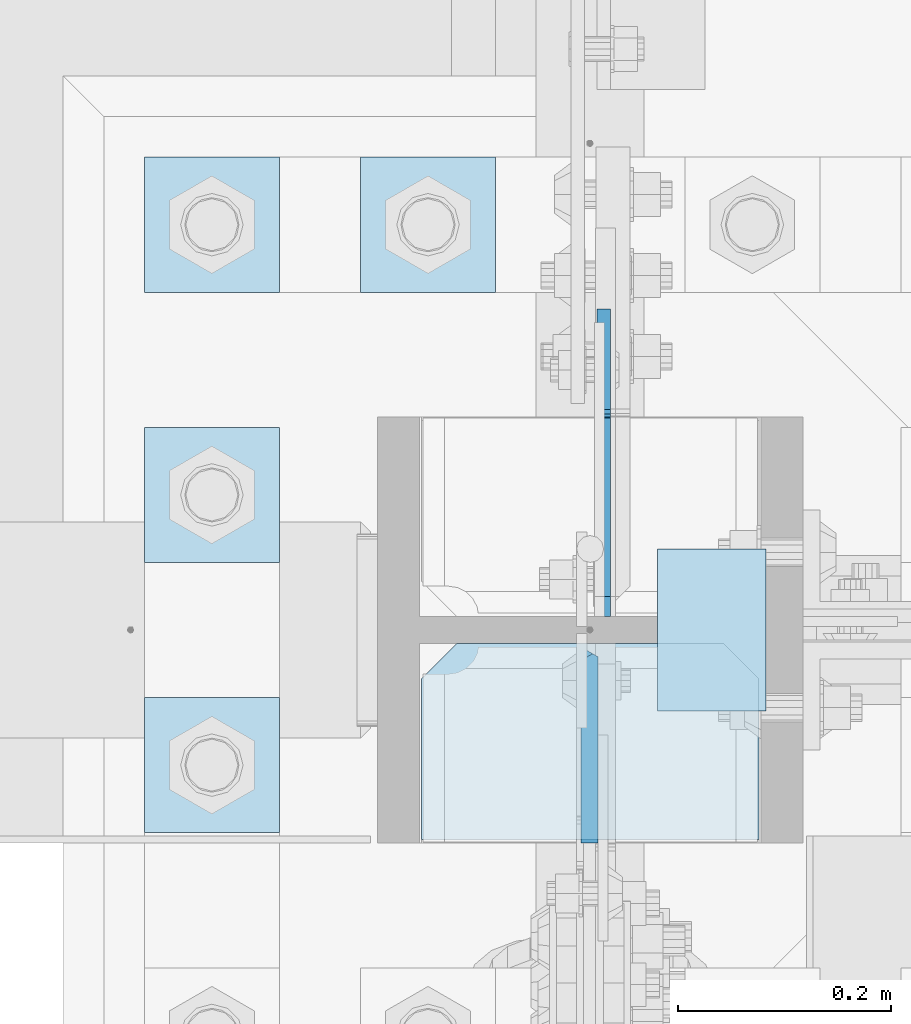
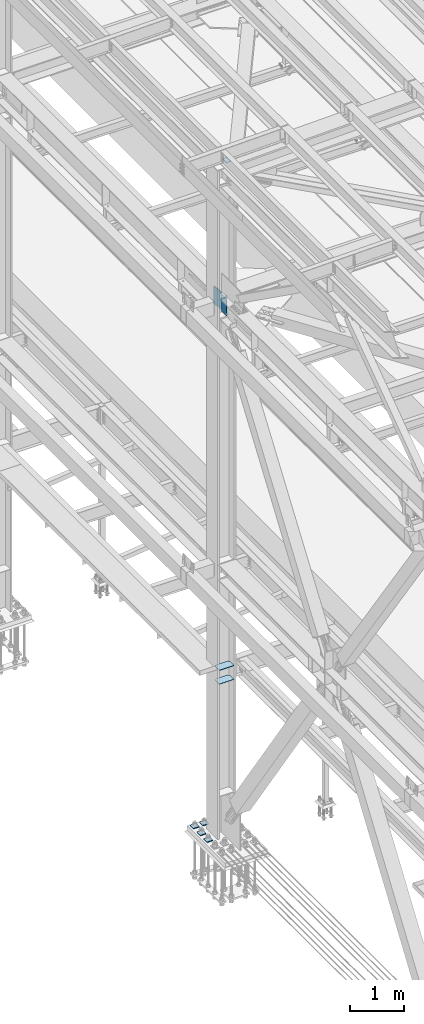
# One storey, part 3272 of 3843: 9 plates, 2 elements without a shape of their own.
"""IFC2X3 building model written with IfcOpenShell, lengths in millimetres."""

from ifc_helpers import new_model, si_unit, frame, origin_with_axes, place, context, subcontext, project, spatial, faceted_brep, material, type_object, element, aggregate, save


model = new_model("IFC2X3")

# Units and contexts
model_context = context("Model", 3, precision=1e-05, world=origin_with_axes())
body_context = subcontext(model_context, "Body", "Model", "MODEL_VIEW")
ifc_project = project(units=[si_unit("LENGTHUNIT", "METRE", prefix="MILLI"), si_unit("AREAUNIT", "SQUARE_METRE"), si_unit("VOLUMEUNIT", "CUBIC_METRE"), si_unit("MASSUNIT", "GRAM", prefix="KILO"), si_unit("TIMEUNIT", "SECOND"), si_unit("PLANEANGLEUNIT", "RADIAN"), si_unit("SOLIDANGLEUNIT", "STERADIAN"), si_unit("THERMODYNAMICTEMPERATUREUNIT", "DEGREE_CELSIUS"), si_unit("LUMINOUSINTENSITYUNIT", "LUMEN")], contexts=[model_context])

# Site, building, storey
site_placement = place(None, origin_with_axes())
site = spatial("IfcSite", under=ifc_project, at=site_placement, CompositionType="ELEMENT")
building_placement = place(site_placement, origin_with_axes())
building = spatial("IfcBuilding", under=site, at=building_placement, Name="Undefined", CompositionType="ELEMENT")
storey_placement = place(building_placement, origin_with_axes())
storey = spatial("IfcBuildingStorey", under=building, at=storey_placement, Name="Undefined", CompositionType="ELEMENT", Elevation=0.0)

# Assembly, plates
assembly_1_placement = place(storey_placement, origin_with_axes())
assembly_1 = element("IfcElementAssembly", 1, at=assembly_1_placement, inside=storey, Name="COLUMN", AssemblyPlace="NOTDEFINED", PredefinedType="RIGID_FRAME")
ifc_material = material(Name="STEEL/A572-50")
plate_type_1 = type_object("IfcPlateType", PredefinedType="NOTDEFINED")
plate_1_placement = place(assembly_1_placement, frame((36639.5, 58991.5000000002, 45422.542188), z_axis=(1.0, 0.0, 0.0), x_axis=(0.0, -1.0, 0.0)))
plate_1 = element("IfcPlate", 2, at=plate_1_placement, type_object=plate_type_1, material=ifc_material, Name="PLATE", context=body_context, shape_type="Brep", body=[
    faceted_brep([(0.0, -3.17499999999927, 0.0), (0.0, -3.17499999999927, 101.600000000006), (0.0, 3.17499999999927, 101.600000000006), (0.0, 3.17499999999927, 0.0), (152.399998474109, -3.17500000000291, 101.599998474121), (152.399998474109, 3.17500000000291, 101.599998474121), (152.399998474109, -3.17500000000291, 0.0), (152.399998474109, 3.17500000000291, 0.0)], [[[0, 1, 2, 3]], [[1, 4, 5, 2]], [[4, 6, 7, 5]], [[6, 0, 3, 7]], [[5, 7, 3, 2]], [[6, 4, 1, 0]]]),
])
plate_type_2 = type_object("IfcPlateType", PredefinedType="NOTDEFINED")
plate_2_placement = place(assembly_1_placement, frame((36575.20625, 58902.5999999997, 42049.7000027761), z_axis=(0.0, -0.707106781186682, 0.707106781186413), x_axis=(0.0, -0.707106781186548, -0.707106781186548)))
plate_2 = element("IfcPlate", 3, at=plate_2_placement, type_object=plate_type_2, material=ifc_material, Name="PLATE", context=body_context, shape_type="Brep", body=[
    faceted_brep([(4.49012799309094, -7.9375, 7.27595761418343e-12), (-258.182363479666, -7.9375, 262.67249147276), (-258.182363479666, 3.06102272230783, 271.652747647553), (-254.200736443892, 7.9375, 271.652747659136), (13.470384184775, 7.9375, 3.98162703046546), (13.4703841731916, 3.06102272879798, -7.27595761418343e-12), (-258.182363479651, -7.9375, 280.633003845527), (-136.94890581214, -7.9375, 401.866457350838), (-130.467612416716, 7.93750000095315, 395.385867526324), (22.4506403026729, -7.93750001103617, 0.0), (137.203156367104, 7.9375, 127.714399254661), (143.684450000859, -7.93749999986903, 121.233809668522), (124.601054452933, 7.9375, 140.3165009773), (124.601054452933, -7.9375, 140.3165009773), (-117.86586234005, 7.9375, 382.783414159065), (-117.86586234005, -7.9375, 382.783414159065)], [[[0, 1, 2, 3, 4, 5]], [[6, 7, 8, 3, 2]], [[9, 0, 5]], [[10, 11, 9, 5, 4]], [[12, 13, 11, 10]], [[14, 15, 13, 12]], [[15, 14, 8, 7]], [[1, 0, 9, 11, 13, 15, 7, 6]], [[6, 2, 1]], [[8, 14, 12, 10, 4, 3]]]),
])
plate_type_3 = type_object("IfcPlateType", PredefinedType="NOTDEFINED")
plate_3_placement = place(assembly_1_placement, frame((36734.75, 58902.6, 33688.3375), z_axis=(-1.0, 0.0, 0.0), x_axis=(0.0, -1.0, 0.0)))
plate_3 = element("IfcPlate", 4, at=plate_3_placement, type_object=plate_type_3, material=ifc_material, Name="PLATE", context=body_context, shape_type="Brep", body=[
    faceted_brep([(0.0, -4.76249999999709, 33.3375015258789), (0.0, -4.76249999999709, 284.162498474121), (0.0, 4.76249999999709, 284.162498474121), (0.0, 4.76249999999709, 33.3375015258789), (33.3375015258789, -4.76249999999709, 317.5), (33.3375015258789, 4.76249999999709, 317.5), (184.150000000009, -4.76249999999709, 317.5), (184.150000000009, 4.76249999999709, 317.5), (184.150000000009, -4.76249999999709, 0.0), (184.150000000009, 4.76249999999709, 0.0), (33.3375015258789, -4.76249999999709, 0.0), (33.3375015258789, 4.76249999999709, 0.0)], [[[0, 1, 2, 3]], [[1, 4, 5, 2]], [[4, 6, 7, 5]], [[6, 8, 9, 7]], [[8, 10, 11, 9]], [[10, 0, 3, 11]], [[5, 7, 9, 11, 3, 2]], [[10, 8, 6, 4, 1, 0]]]),
])
plate_4_placement = place(assembly_1_placement, frame((36734.75, 58902.6, 34002.6625), z_axis=(-1.0, 0.0, 0.0), x_axis=(0.0, -1.0, 0.0)))
plate_4 = element("IfcPlate", 5, at=plate_4_placement, type_object=plate_type_3, material=ifc_material, Name="PLATE", context=body_context, shape_type="Brep", body=[
    faceted_brep([(0.0, -4.76249999999709, 33.3375015258789), (0.0, -4.76249999999709, 284.162498474121), (0.0, 4.76249999999709, 284.162498474121), (0.0, 4.76249999999709, 33.3375015258789), (33.3375015258789, -4.76249999999709, 317.5), (33.3375015258789, 4.76249999999709, 317.5), (184.150000000009, -4.76249999999709, 317.5), (184.150000000009, 4.76249999999709, 317.5), (184.150000000009, -4.76249999999709, 0.0), (184.150000000009, 4.76249999999709, 0.0), (33.3375015258789, -4.76249999999709, 0.0), (33.3375015258789, 4.76249999999709, 0.0)], [[[0, 1, 2, 3]], [[1, 4, 5, 2]], [[4, 6, 7, 5]], [[6, 8, 9, 7]], [[8, 10, 11, 9]], [[10, 0, 3, 11]], [[5, 7, 9, 11, 3, 2]], [[10, 8, 6, 4, 1, 0]]]),
])
plate_type_4 = type_object("IfcPlateType", PredefinedType="NOTDEFINED")
plate_5_placement = place(assembly_1_placement, frame((36588.7000000954, 58928.0, 42049.7), z_axis=(0.0, 0.707106781186548, 0.707106781186548), x_axis=(5.70000238222118e-08, 0.707106781186546, -0.707106781186546)))
plate_5 = element("IfcPlate", 6, at=plate_5_placement, type_object=plate_type_4, material=ifc_material, Name="PLATE", context=body_context, shape_type="Brep", body=[
    faceted_brep([(0.0, -6.3499999046162, 0.0), (-258.182363479495, -6.34999999999854, 258.182363479486), (-258.182363479495, 6.34999999999854, 258.182363479486), (7.27595761418343e-12, 6.3499999046162, 0.0), (-258.18236347936, -6.34999999999854, 285.123131842716), (-258.18236347936, 6.34999999999854, 285.123131842716), (-139.755235882103, -6.34999999999854, 403.550259439973), (-139.755235882103, 6.34999999999854, 403.550259439973), (-133.020043656483, -6.34999999999854, 396.815067214353), (-133.020043656483, 6.34999999999854, 396.815067214353), (-128.899867188344, -6.34999999999854, 394.062053313872), (-128.899867188344, 6.34999999999854, 394.062053313872), (-124.039787670305, -6.34999999999854, 393.095323391288), (-124.039787670305, 6.34999999999854, 393.095323391288), (-119.179708152273, -6.34999999999854, 394.062053313872), (-119.179708152273, 6.34999999999854, 394.062053313872), (-115.059531684126, -6.34999999999854, 396.815067214353), (-115.059531684126, 6.34999999999854, 396.815067214353), (-51.6364726937954, -6.34999999999854, 460.238126204684), (-51.6364726937954, 6.34999999999854, 460.238126204684), (226.751467058011, -6.34999999999854, 181.850186452881), (226.751467058011, 6.34999999999854, 181.850186452881), (154.348152081502, -6.34999999999854, 109.446871476364), (154.348152081502, 6.34999999999854, 109.446871476364), (145.367895960471, -6.34999999999854, 118.427127597388), (145.367895960471, 6.34999999999854, 118.427127597388), (26.9407683632217, -6.34999999999854, 1.30967237055302e-10), (26.9407683632217, 6.34999999999854, 1.30967237055302e-10)], [[[0, 1, 2, 3]], [[1, 4, 5, 2]], [[4, 6, 7, 5]], [[6, 8, 9, 7]], [[8, 10, 11, 9]], [[10, 12, 13, 11]], [[12, 14, 15, 13]], [[14, 16, 17, 15]], [[16, 18, 19, 17]], [[18, 20, 21, 19]], [[20, 22, 23, 21]], [[22, 24, 25, 23]], [[24, 26, 27, 25]], [[26, 0, 3, 27]], [[5, 7, 9, 11, 13, 15, 17, 19, 21, 23, 25, 27, 3, 2]], [[26, 24, 22, 20, 18, 16, 14, 12, 10, 8, 6, 4, 1, 0]]]),
])
aggregate(assembly_1, [plate_1, plate_2, plate_3, plate_4, plate_5])

assembly_2_placement = place(storey_placement, origin_with_axes())
assembly_2 = element("IfcElementAssembly", 7, at=assembly_2_placement, inside=storey, Name="TEMPLATE", AssemblyPlace="NOTDEFINED", PredefinedType="RIGID_FRAME")
plate_type_5 = type_object("IfcPlateType", PredefinedType="NOTDEFINED")
plate_6_placement = place(assembly_2_placement, frame((36360.1, 59359.8, 30172.025), z_axis=(0.0, -1.0, 0.0), x_axis=(1.0, 0.0, 0.0)))
plate_6 = element("IfcPlate", 8, at=plate_6_placement, type_object=plate_type_5, material=ifc_material, Name="Washer Plate", context=body_context, shape_type="Brep", body=[
    faceted_brep([(0.0, -9.52500000000146, 0.0), (0.0, -9.52499999999418, 127.0), (0.0, 9.52499999999418, 127.0), (0.0, 9.52500000000146, 0.0), (127.0, -9.52500000000146, 127.0), (127.0, 9.52500000000146, 127.0), (127.0, -9.52500000000146, 0.0), (127.0, 9.52500000000146, 0.0)], [[[0, 1, 2, 3]], [[1, 4, 5, 2]], [[4, 6, 7, 5]], [[6, 0, 3, 7]], [[5, 7, 3, 2]], [[6, 4, 1, 0]]]),
])
plate_7_placement = place(assembly_2_placement, frame((36156.9, 58851.8, 30172.025), z_axis=(0.0, -1.0, 0.0), x_axis=(1.0, 0.0, 0.0)))
plate_7 = element("IfcPlate", 9, at=plate_7_placement, type_object=plate_type_5, material=ifc_material, Name="Washer Plate", context=body_context, shape_type="Brep", body=[
    faceted_brep([(0.0, -9.52500000000146, 0.0), (0.0, -9.52499999999418, 127.0), (0.0, 9.52499999999418, 127.0), (0.0, 9.52500000000146, 0.0), (127.0, -9.52500000000146, 127.0), (127.0, 9.52500000000146, 127.0), (127.0, -9.52500000000146, 0.0), (127.0, 9.52500000000146, 0.0)], [[[0, 1, 2, 3]], [[1, 4, 5, 2]], [[4, 6, 7, 5]], [[6, 0, 3, 7]], [[5, 7, 3, 2]], [[6, 4, 1, 0]]]),
])
plate_8_placement = place(assembly_2_placement, frame((36156.9, 59105.8, 30172.025), z_axis=(0.0, -1.0, 0.0), x_axis=(1.0, 0.0, 0.0)))
plate_8 = element("IfcPlate", 10, at=plate_8_placement, type_object=plate_type_5, material=ifc_material, Name="Washer Plate", context=body_context, shape_type="Brep", body=[
    faceted_brep([(0.0, -9.52500000000146, 0.0), (0.0, -9.52499999999418, 127.0), (0.0, 9.52499999999418, 127.0), (0.0, 9.52500000000146, 0.0), (127.0, -9.52500000000146, 127.0), (127.0, 9.52500000000146, 127.0), (127.0, -9.52500000000146, 0.0), (127.0, 9.52500000000146, 0.0)], [[[0, 1, 2, 3]], [[1, 4, 5, 2]], [[4, 6, 7, 5]], [[6, 0, 3, 7]], [[5, 7, 3, 2]], [[6, 4, 1, 0]]]),
])
plate_9_placement = place(assembly_2_placement, frame((36156.9, 59359.8, 30172.025), z_axis=(0.0, -1.0, 0.0), x_axis=(1.0, 0.0, 0.0)))
plate_9 = element("IfcPlate", 11, at=plate_9_placement, type_object=plate_type_5, material=ifc_material, Name="Washer Plate", context=body_context, shape_type="Brep", body=[
    faceted_brep([(0.0, -9.52500000000146, 0.0), (0.0, -9.52499999999418, 127.0), (0.0, 9.52499999999418, 127.0), (0.0, 9.52500000000146, 0.0), (127.0, -9.52500000000146, 127.0), (127.0, 9.52500000000146, 127.0), (127.0, -9.52500000000146, 0.0), (127.0, 9.52500000000146, 0.0)], [[[0, 1, 2, 3]], [[1, 4, 5, 2]], [[4, 6, 7, 5]], [[6, 0, 3, 7]], [[5, 7, 3, 2]], [[6, 4, 1, 0]]]),
])
aggregate(assembly_2, [plate_6, plate_7, plate_8, plate_9])

save(model, "model.ifc")
